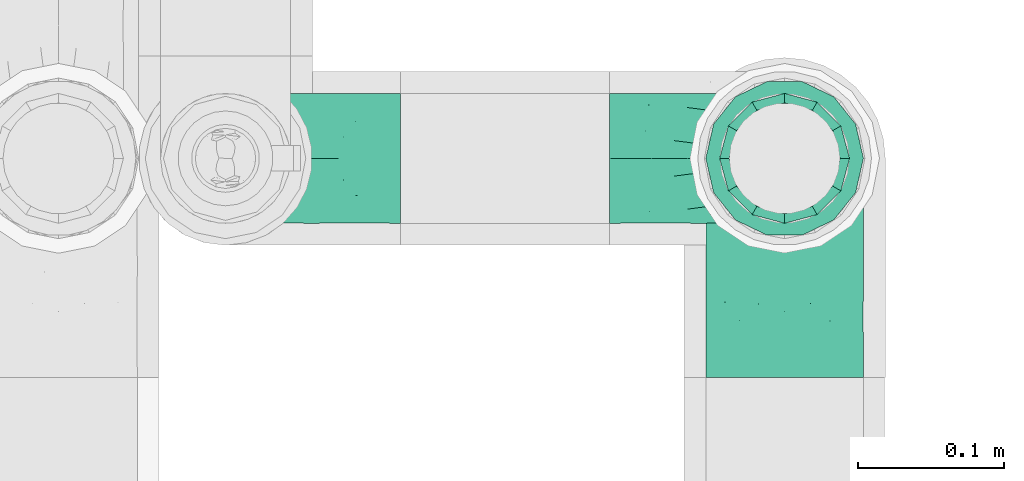
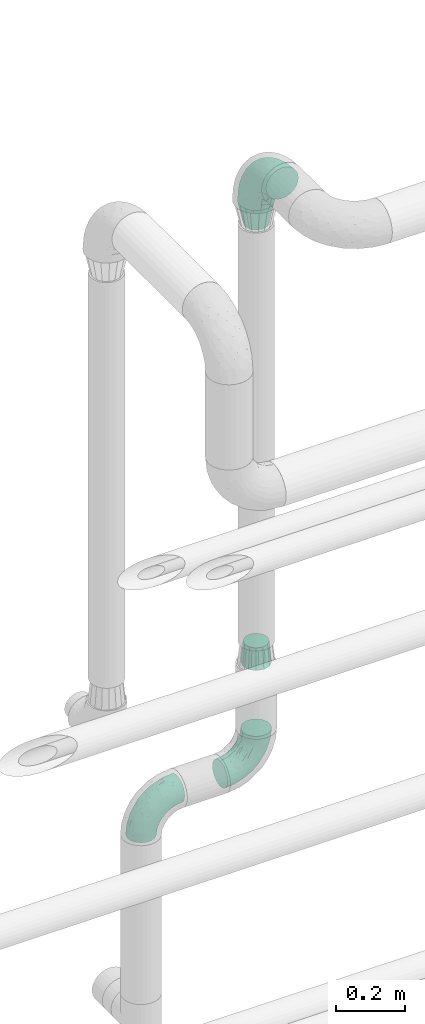
# One storey, part 721 of 827: 5 flow fittings.
"""IFC2X3 building model written with IfcOpenShell, lengths in millimetres."""

import ifcopenshell
import ifcopenshell.guid

model = None  # the IFC model being written
_history = None  # IfcOwnerHistory: only IFC2X3 demands one
_inside = {}  # id of a spatial element -> (the spatial element, [elements in it])
_under = {}  # id of a project, library or spatial element -> (it, [spatial elements below it])
_declared = {}  # id of a project -> (the project, [libraries it declares])
_typed = {}  # id of a type object -> (the type object, [elements of that type])
_made_of = {}  # id of a material, layer set ... -> (it, [elements and type objects made of it])


def new_model(schema):
    """Start an empty IFC model of exactly this schema.

    Asked for "IFC4X3", IfcOpenShell would pick the latest addendum, in which some entities
    have other attributes; the version numbers below select the first issue.
    IFC2X3 requires an IfcOwnerHistory on every rooted entity: one is made here for all.
    """
    global model, _history
    if schema == "IFC4X3":
        model = ifcopenshell.file(schema_version=(4, 3, 0, 0))
    else:
        model = ifcopenshell.file(schema=schema)
    _inside.clear()
    _under.clear()
    _declared.clear()
    _typed.clear()
    _made_of.clear()
    _history = None
    if model.schema == "IFC2X3":
        org = make("IfcOrganization", Name="unknown")
        user = make(
            "IfcPersonAndOrganization",
            ThePerson=make("IfcPerson", FamilyName="unknown"),
            TheOrganization=org,
        )
        app = make(
            "IfcApplication",
            ApplicationDeveloper=org,
            Version="unknown",
            ApplicationFullName="unknown",
            ApplicationIdentifier="unknown",
        )
        _history = make(
            "IfcOwnerHistory",
            OwningUser=user,
            OwningApplication=app,
            ChangeAction="ADDED",
            CreationDate=0,
        )
    return model


def make(cls, **values):
    """One entity of the class cls with the attributes given. An attribute that is None is left unset."""
    return model.create_entity(
        cls, **{name: value for name, value in values.items() if value is not None}
    )


def entity(cls, *values):
    """Any entity or typed value of the class cls, its attributes in the order of the schema. None: left unset."""
    e = model.create_entity(cls)
    for i, value in enumerate(values):
        if value is not None:
            e[i] = value
    return e


def rooted(cls, **values):
    """An entity with a GlobalId (a new one), such as an element, a storey or a relation."""
    return make(cls, GlobalId=ifcopenshell.guid.new(), OwnerHistory=_history, **values)


def si_unit(unit_type, name, prefix=None):
    """IfcSIUnit, for example si_unit("LENGTHUNIT", "METRE", prefix="MILLI")."""
    return make("IfcSIUnit", UnitType=unit_type, Prefix=prefix, Name=name)


def converted_unit(unit_type, name, factor, base, dimensions=None, offset=None):
    """IfcConversionBasedUnit, such as the inch: factor (a typed value) times the base unit."""
    return make(
        "IfcConversionBasedUnit"
        if offset is None
        else "IfcConversionBasedUnitWithOffset",
        ConversionOffset=offset,
        Dimensions=None
        if dimensions is None
        else entity("IfcDimensionalExponents", *dimensions),
        UnitType=unit_type,
        Name=name,
        ConversionFactor=make(
            "IfcMeasureWithUnit", ValueComponent=factor, UnitComponent=base
        ),
    )


def derived_unit(unit_type, elements):
    """IfcDerivedUnit: a product of units, each with its exponent."""
    return make(
        "IfcDerivedUnit",
        Elements=[
            make("IfcDerivedUnitElement", Unit=unit, Exponent=power)
            for unit, power in elements
        ],
        UnitType=unit_type,
    )


def assignment(units):
    """IfcUnitAssignment: the units of a project."""
    return None if units is None else make("IfcUnitAssignment", Units=units)


def point(xyz):
    """IfcCartesianPoint."""
    return None if xyz is None else make("IfcCartesianPoint", Coordinates=xyz)


def direction(xyz):
    """IfcDirection."""
    return None if xyz is None else make("IfcDirection", DirectionRatios=xyz)


def frame(location, z_axis=None, x_axis=None):
    """IfcAxis2Placement3D, a coordinate frame: its origin and axes. An axis left out is left unset."""
    return make(
        "IfcAxis2Placement3D",
        Location=point(location),
        Axis=direction(z_axis),
        RefDirection=direction(x_axis),
    )


def origin():
    """The frame at (0, 0, 0) with its axes left unset."""
    return frame((0.0, 0.0, 0.0))


def place(relative_to, where):
    """IfcLocalPlacement: puts the frame where relative to a parent placement (None: the world)."""
    return make(
        "IfcLocalPlacement", PlacementRelTo=relative_to, RelativePlacement=where
    )


def context(
    kind, dimensions, precision=None, world=None, true_north=None, identifier=None
):
    """IfcGeometricRepresentationContext, for example the 3D "Model" context."""
    return make(
        "IfcGeometricRepresentationContext",
        ContextIdentifier=identifier,
        ContextType=kind,
        CoordinateSpaceDimension=dimensions,
        Precision=precision,
        WorldCoordinateSystem=world,
        TrueNorth=true_north,
    )


def subcontext(parent, identifier, kind, view, scale=None):
    """IfcGeometricRepresentationSubContext, for example "Body" below "Model"."""
    return make(
        "IfcGeometricRepresentationSubContext",
        ContextIdentifier=identifier,
        ContextType=kind,
        ParentContext=parent,
        TargetScale=scale,
        TargetView=view,
    )


def project(units=None, contexts=None):
    """IfcProject with its units and contexts."""
    return rooted(
        "IfcProject",
        Name="project",
        RepresentationContexts=contexts,
        UnitsInContext=assignment(units),
    )


def spatial(cls, under=None, at=None, **own):
    """A site, building, storey or space (cls), placed at a placement, below another one or the project."""
    s = rooted(cls, ObjectPlacement=at, **own)
    if under is not None:
        _under.setdefault(under.id(), (under, []))[1].append(s)
    return s


def faces_of(points, faces, orient=None, outer=None):
    """IfcFace entities. A face is a list of loops; a loop is a list of indices into points, from 0.

    orient and outer hold one flag for each loop. By default every Orientation is true, the
    first loop of a face is its IfcFaceOuterBound and the others are IfcFaceBound.
    """
    made = []
    for i, loops in enumerate(faces):
        bounds = []
        for j, loop in enumerate(loops):
            is_outer = j == 0 if outer is None else outer[i][j]
            bounds.append(
                make(
                    "IfcFaceOuterBound" if is_outer else "IfcFaceBound",
                    Bound=make("IfcPolyLoop", Polygon=[points[k] for k in loop]),
                    Orientation=True if orient is None else orient[i][j],
                )
            )
        made.append(make("IfcFace", Bounds=bounds))
    return made


def faceted_brep(points, faces, orient=None, outer=None, voids=None):
    """IfcFacetedBrep: a solid bounded by flat faces; with voids (closed shells), ...WithVoids."""
    shared = [point(p) for p in points]
    hull = make("IfcClosedShell", CfsFaces=faces_of(shared, faces, orient, outer))
    if voids is None:
        return make("IfcFacetedBrep", Outer=hull)
    return make(
        "IfcFacetedBrepWithVoids",
        Outer=hull,
        Voids=[
            make(cls, CfsFaces=faces_of(shared, fs, o, b)) for cls, fs, o, b in voids
        ],
    )


def shape(context_of_items, identifier, shape_type, items):
    """IfcShapeRepresentation: the items that make up one representation, for example the "Body"."""
    return make(
        "IfcShapeRepresentation",
        ContextOfItems=context_of_items,
        RepresentationIdentifier=identifier,
        RepresentationType=shape_type,
        Items=items,
    )


def source(mapping_origin, context_of_items, identifier, shape_type, items):
    """IfcRepresentationMap: a shape defined once, which mapped items show again and again."""
    return make(
        "IfcRepresentationMap",
        MappingOrigin=mapping_origin,
        MappedRepresentation=shape(context_of_items, identifier, shape_type, items),
    )


def transform(
    local_origin,
    x_axis=None,
    y_axis=None,
    z_axis=None,
    scale=None,
    scale2=None,
    scale3=None,
    uniform=True,
):
    """IfcCartesianTransformationOperator3D, or its non-uniform kind. x_axis, y_axis, z_axis: its Axis1, 2, 3."""
    if uniform:
        return make(
            "IfcCartesianTransformationOperator3D",
            Axis1=direction(x_axis),
            Axis2=direction(y_axis),
            LocalOrigin=point(local_origin),
            Scale=scale,
            Axis3=direction(z_axis),
        )
    return make(
        "IfcCartesianTransformationOperator3DnonUniform",
        Axis1=direction(x_axis),
        Axis2=direction(y_axis),
        LocalOrigin=point(local_origin),
        Scale=scale,
        Axis3=direction(z_axis),
        Scale2=scale2,
        Scale3=scale3,
    )


def mapped(mapping_source, mapping_target):
    """IfcMappedItem: shows the shape of a source again, moved by a transform."""
    return make(
        "IfcMappedItem", MappingSource=mapping_source, MappingTarget=mapping_target
    )


def material(Name=None, Category=None):
    """IfcMaterial."""
    return make("IfcMaterial", Name=Name, Category=Category)


def made_of(thing, what):
    """Note that an element or type object is made of a material, layer set ...; save() writes the relation."""
    if what is not None:
        _made_of.setdefault(what.id(), (what, []))[1].append(thing)
    return thing


def type_object(cls, material=None, **own):
    """A type object (cls), such as IfcWallType, which elements share."""
    return made_of(rooted(cls, **own), material)


def type_shapes(of_type, sources):
    """Give a type object the sources (RepresentationMaps) that its elements show as mapped items."""
    of_type.RepresentationMaps = sources


def element(
    cls,
    number,
    at=None,
    inside=None,
    cuts=None,
    type_object=None,
    material=None,
    context=None,
    identifier="Body",
    shape_type=None,
    held_by="IfcProductDefinitionShape",
    body=None,
    shapes=None,
    **own,
):
    """One element of the class cls, such as IfcWall. Its Tag is "e" and its number.

    at: its placement. inside: the storey or other place that contains it. cuts: it is an
    opening in that element (IfcRelVoidsElement). A single representation is given by context,
    identifier, shape_type and body (its items); several are given by shapes. held_by: the class
    of the entity that holds the representations. save() writes the other relations.
    """
    e = rooted(cls, Tag="e%d" % number, ObjectPlacement=at, **own)
    if body is not None:
        shapes = [shape(context, identifier, shape_type, body)]
    if shapes is not None:
        e.Representation = make(held_by, Representations=shapes)
    if inside is not None:
        _inside.setdefault(inside.id(), (inside, []))[1].append(e)
    if cuts is not None:
        rooted(
            "IfcRelVoidsElement", RelatingBuildingElement=cuts, RelatedOpeningElement=e
        )
    if type_object is not None:
        _typed.setdefault(type_object.id(), (type_object, []))[1].append(e)
    return made_of(e, material)


def aggregate(whole, parts):
    """IfcRelAggregates: a whole, such as a stair, and the parts it consists of."""
    return rooted("IfcRelAggregates", RelatingObject=whole, RelatedObjects=parts)


def save(model, path):
    """Write the relations noted so far, then the file.

    IfcRelAggregates (storeys below a building ...), IfcRelContainedInSpatialStructure (elements
    in a storey), IfcRelDefinesByType, IfcRelAssociatesMaterial and IfcRelDeclares: one each for
    every whole, place, type object, material and project.
    """
    for whole, parts in _under.values():
        aggregate(whole, parts)
    for where, things in _inside.values():
        rooted(
            "IfcRelContainedInSpatialStructure",
            RelatedElements=things,
            RelatingStructure=where,
        )
    for kind, things in _typed.values():
        rooted("IfcRelDefinesByType", RelatedObjects=things, RelatingType=kind)
    for what, things in _made_of.values():
        rooted("IfcRelAssociatesMaterial", RelatedObjects=things, RelatingMaterial=what)
    for by, libraries in _declared.values():
        rooted("IfcRelDeclares", RelatingContext=by, RelatedDefinitions=libraries)
    model.write(path)


model = new_model("IFC2X3")

# Units and contexts
model_context = context("Model", 3, precision=0.01, world=origin(), true_north=direction((6.12303176911189e-17, 1.0)))
body_context = subcontext(model_context, "Body", "Model", "MODEL_VIEW")
ifc_project = project(units=[si_unit("LENGTHUNIT", "METRE", prefix="MILLI"), si_unit("AREAUNIT", "SQUARE_METRE"), si_unit("VOLUMEUNIT", "CUBIC_METRE"), converted_unit("PLANEANGLEUNIT", "DEGREE", entity("IfcRatioMeasure", 0.0174532925199433), si_unit("PLANEANGLEUNIT", "RADIAN"), dimensions=[0, 0, 0, 0, 0, 0, 0]), si_unit("MASSUNIT", "GRAM", prefix="KILO"), derived_unit("MASSDENSITYUNIT", [(si_unit("MASSUNIT", "GRAM", prefix="KILO"), 1), (si_unit("LENGTHUNIT", "METRE"), -3)]), derived_unit("MOMENTOFINERTIAUNIT", [(si_unit("LENGTHUNIT", "METRE"), 4)]), si_unit("TIMEUNIT", "SECOND"), si_unit("FREQUENCYUNIT", "HERTZ"), si_unit("THERMODYNAMICTEMPERATUREUNIT", "DEGREE_CELSIUS"), derived_unit("THERMALTRANSMITTANCEUNIT", [(si_unit("MASSUNIT", "GRAM", prefix="KILO"), 1), (si_unit("THERMODYNAMICTEMPERATUREUNIT", "KELVIN"), -1), (si_unit("TIMEUNIT", "SECOND"), -3)]), derived_unit("VOLUMETRICFLOWRATEUNIT", [(si_unit("LENGTHUNIT", "METRE"), 3), (si_unit("TIMEUNIT", "SECOND"), -1)]), derived_unit("MASSFLOWRATEUNIT", [(si_unit("MASSUNIT", "GRAM", prefix="KILO"), 1), (si_unit("TIMEUNIT", "SECOND"), -1)]), derived_unit("ROTATIONALFREQUENCYUNIT", [(si_unit("TIMEUNIT", "SECOND"), -1)]), si_unit("ELECTRICCURRENTUNIT", "AMPERE"), si_unit("ELECTRICVOLTAGEUNIT", "VOLT"), si_unit("POWERUNIT", "WATT"), si_unit("FORCEUNIT", "NEWTON", prefix="KILO"), si_unit("ILLUMINANCEUNIT", "LUX"), si_unit("LUMINOUSFLUXUNIT", "LUMEN"), si_unit("LUMINOUSINTENSITYUNIT", "CANDELA"), derived_unit("USERDEFINED", [(si_unit("MASSUNIT", "GRAM", prefix="KILO"), -1), (si_unit("LENGTHUNIT", "METRE"), -2), (si_unit("TIMEUNIT", "SECOND"), 3), (si_unit("LUMINOUSFLUXUNIT", "LUMEN"), 1)]), derived_unit("LINEARVELOCITYUNIT", [(si_unit("LENGTHUNIT", "METRE"), 1), (si_unit("TIMEUNIT", "SECOND"), -1)]), si_unit("PRESSUREUNIT", "PASCAL"), derived_unit("USERDEFINED", [(si_unit("LENGTHUNIT", "METRE"), -2), (si_unit("MASSUNIT", "GRAM", prefix="KILO"), 1), (si_unit("TIMEUNIT", "SECOND"), -2)]), derived_unit("LINEARFORCEUNIT", [(si_unit("MASSUNIT", "GRAM", prefix="KILO"), 1), (si_unit("LENGTHUNIT", "METRE"), 1), (si_unit("TIMEUNIT", "SECOND"), -2), (si_unit("LENGTHUNIT", "METRE"), -1)]), derived_unit("PLANARFORCEUNIT", [(si_unit("MASSUNIT", "GRAM", prefix="KILO"), 1), (si_unit("LENGTHUNIT", "METRE"), 1), (si_unit("TIMEUNIT", "SECOND"), -2), (si_unit("LENGTHUNIT", "METRE"), -2)])], contexts=[model_context])

# Site, building, storey
site_placement = place(None, origin())
site = spatial("IfcSite", under=ifc_project, at=site_placement, CompositionType="ELEMENT")
building_placement = place(site_placement, origin())
building = spatial("IfcBuilding", under=site, at=building_placement, CompositionType="ELEMENT")
storey_placement = place(building_placement, frame((0.0, 0.0, 28200.0)))
storey = spatial("IfcBuildingStorey", under=building, at=storey_placement, Name="08", CompositionType="ELEMENT", Elevation=28200.0)

# Flow fittings
ifc_material = material()
pipe_fitting_type_1 = type_object("IfcPipeFittingType", Name="ADSK_2", PredefinedType="NOTDEFINED", material=ifc_material)
shared_shape_1 = source(origin(), body_context, "Body", "Brep", [
    faceted_brep([(-150.0, 13.98, -52.16), (-150.0, 0.0, -54.0), (-150.0, -13.98, -52.16), (-150.0, -27.0, -46.77), (-150.0, -38.18, -38.18), (-150.0, -46.77, -27.0), (-150.0, -52.16, -13.98), (-150.0, -54.0, 0.0), (-150.0, -52.16, 13.98), (-150.0, -46.77, 27.0), (-150.0, -38.18, 38.18), (-150.0, -27.0, 46.77), (-150.0, -13.98, 52.16), (-150.0, 0.0, 54.0), (-150.0, 13.98, 52.16), (-150.0, 27.0, 46.77), (-150.0, 38.18, 38.18), (-150.0, 46.77, 27.0), (-150.0, 52.16, 13.98), (-150.0, 54.0, 0.0), (-150.0, 52.16, -13.98), (-150.0, 46.77, -27.0), (-150.0, 38.18, -38.18), (-150.0, 27.0, -46.77), (-46.77, 150.0, -27.0), (-52.16, 150.0, -13.98), (-54.0, 150.0, 0.0), (-52.16, 150.0, 13.98), (-46.77, 150.0, 27.0), (-38.18, 150.0, 38.18), (-27.0, 150.0, 46.77), (-13.98, 150.0, 52.16), (0.0, 150.0, 54.0), (13.98, 150.0, 52.16), (27.0, 150.0, 46.77), (38.18, 150.0, 38.18), (46.77, 150.0, 27.0), (52.16, 150.0, 13.98), (54.0, 150.0, 0.0), (52.16, 150.0, -13.98), (46.77, 150.0, -27.0), (38.18, 150.0, -38.18), (27.0, 150.0, -46.77), (13.98, 150.0, -52.16), (0.0, 150.0, -54.0), (-13.98, 150.0, -52.16), (-27.0, 150.0, -46.77), (-38.18, 150.0, -38.18), (-23.02, 116.05, 50.71), (-10.79, 106.96, 53.83), (-99.79, -44.6, 17.82), (-104.61, -48.89, 0.0), (-111.52, -18.45, 48.95), (-64.27, -5.9, 46.22), (-79.66, 4.7, 52.78), (-22.81, -9.49, 0.0), (-44.33, -22.22, 14.35), (-61.49, -33.8, 0.0), (-111.02, -40.26, 31.0), (-106.96, 10.79, 53.83), (-75.79, 19.35, 54.0), (-83.79, 28.63, 52.71), (-6.35, 6.35, 9.57), (22.22, 44.33, 14.35), (-8.95, 8.95, 21.66), (-70.7, -34.05, 19.37), (-77.79, -39.89, 9.53), (-98.78, -28.03, 40.91), (-35.45, -0.96, 36.82), (-24.08, 24.08, 46.13), (-116.99, -5.61, 53.23), (-84.48, 39.18, 49.64), (-116.05, 23.02, 50.71), (28.03, 98.78, 40.91), (-30.84, 79.95, 52.7), (-19.51, 75.72, 54.0), (-52.23, 125.53, 22.23), (-63.5, 102.33, 17.08), (-52.58, 23.63, 53.15), (-23.76, 41.59, 51.45), (-36.39, 47.25, 53.91), (-58.7, 120.33, 0.0), (-125.53, 52.23, 22.23), (-102.33, 63.5, 17.08), (-120.33, 58.7, 0.0), (-59.32, 99.83, 27.68), (-79.36, 79.36, 20.15), (-75.61, 75.61, 30.15), (-114.52, 47.22, 34.83), (-126.22, 33.98, 43.81), (-93.57, 72.33, 0.0), (-47.51, 113.57, 34.88), (18.45, 111.52, 48.95), (5.61, 116.99, 53.23), (48.89, 104.61, 0.0), (44.6, 99.79, 17.82), (37.15, 71.79, 11.16), (5.9, 64.27, 46.22), (-4.7, 79.66, 52.78), (35.09, 74.65, 20.78), (40.26, 111.02, 31.0), (26.44, 65.11, 28.6), (-65.6, -16.94, 39.27), (-65.11, -26.44, 28.6), (-81.51, 81.51, 9.56), (-72.33, 93.57, 0.0), (9.49, 22.81, 0.0), (-35.64, -11.82, 24.43), (-34.23, 124.56, 43.88), (-43.22, 94.57, 45.11), (-69.02, 56.15, 47.3), (-59.26, 74.56, 43.5), (-78.28, 61.88, 39.9), (18.71, 65.93, 37.87), (0.96, 35.45, 36.82), (-59.2, 87.93, 36.27), (33.8, 61.49, 0.0), (-97.33, 42.02, 44.99), (-99.65, 59.35, 27.78), (-56.16, 9.04, 50.42), (11.82, 35.64, 24.43), (-49.6, 72.87, 48.67), (-34.04, 93.29, 49.78), (-57.05, 51.22, 52.06), (-124.56, 34.23, -43.88), (-98.78, -28.03, -40.91), (-79.66, 4.7, -52.78), (-116.99, -5.61, -53.23), (-106.96, 10.79, -53.83), (-99.83, 59.32, -27.68), (-113.57, 47.51, -34.88), (-125.53, 52.23, -22.23), (-116.05, 23.02, -50.71), (-79.95, 30.84, -52.7), (-47.22, 114.52, -34.83), (-102.33, 63.5, -17.08), (40.26, 111.02, -31.0), (-81.51, 81.51, -9.56), (-52.23, 125.53, -22.23), (-94.57, 43.22, -45.11), (-64.27, -5.9, -46.22), (-35.45, -0.96, -36.82), (-65.93, -18.71, -37.87), (-99.79, -44.6, -17.82), (-47.25, 36.39, -53.91), (-75.72, 19.51, -54.0), (-39.18, 84.48, -49.64), (-23.02, 116.05, -50.71), (-28.63, 83.79, -52.71), (-111.02, -40.26, -31.0), (-10.79, 106.96, -53.83), (-19.35, 75.79, -54.0), (-44.33, -22.22, -14.35), (-8.95, 8.95, -21.66), (-6.35, 6.35, -9.57), (-71.79, -37.15, -11.16), (-61.88, 78.28, -39.9), (-74.56, 59.26, -43.5), (-87.93, 59.2, -36.27), (-74.65, -35.09, -20.78), (-65.11, -26.44, -28.6), (0.96, 35.45, -36.82), (-63.5, 102.33, -17.08), (-79.36, 79.36, -20.15), (18.45, 111.52, -48.95), (5.9, 64.27, -46.22), (-4.7, 79.66, -52.78), (-75.61, 75.61, -30.15), (-33.98, 126.22, -43.81), (5.61, 116.99, -53.23), (-23.63, 52.58, -53.15), (-41.59, 23.76, -51.45), (22.22, 44.33, -14.35), (-56.15, 69.02, -47.3), (28.03, 98.78, -40.91), (39.89, 77.79, -9.53), (34.05, 70.7, -19.37), (-111.52, -18.45, -48.95), (44.6, 99.79, -17.82), (26.44, 65.11, -28.6), (11.82, 35.64, -24.43), (16.94, 65.6, -39.27), (-42.02, 97.33, -44.99), (-59.35, 99.65, -27.78), (-24.08, 24.08, -46.13), (-9.04, 56.16, -50.42), (-35.64, -11.82, -24.43), (-72.87, 49.6, -48.67), (-93.29, 34.04, -49.78), (-51.22, 57.05, -52.06)], [[[0, 1, 2, 3, 4, 5, 6, 7, 8, 9, 10, 11, 12, 13, 14, 15, 16, 17, 18, 19, 20, 21, 22, 23]], [[24, 25, 26, 27, 28, 29, 30, 31, 32, 33, 34, 35, 36, 37, 38, 39, 40, 41, 42, 43, 44, 45, 46, 47]], [[31, 48, 49]], [[50, 8, 51]], [[52, 53, 54]], [[8, 50, 9]], [[8, 7, 51]], [[55, 56, 57]], [[58, 9, 50]], [[59, 60, 61]], [[62, 63, 64]], [[65, 66, 56]], [[11, 10, 67]], [[53, 68, 69]], [[67, 52, 11]], [[70, 59, 13]], [[71, 72, 61]], [[73, 35, 34]], [[74, 75, 49]], [[72, 15, 14]], [[13, 59, 14]], [[76, 27, 77]], [[12, 70, 13]], [[78, 79, 80]], [[27, 81, 77]], [[18, 82, 83]], [[72, 14, 59]], [[84, 19, 18]], [[85, 86, 87]], [[88, 16, 89]], [[84, 83, 90]], [[84, 18, 83]], [[15, 89, 16]], [[85, 91, 76]], [[92, 73, 34]], [[49, 32, 31]], [[93, 33, 32]], [[31, 30, 48]], [[94, 95, 96]], [[94, 37, 95]], [[73, 92, 97]], [[98, 93, 49]], [[11, 52, 12]], [[36, 95, 37]], [[99, 100, 101]], [[95, 36, 100]], [[63, 96, 99]], [[100, 36, 35]], [[102, 53, 67]], [[38, 37, 94]], [[92, 34, 33]], [[103, 67, 58]], [[81, 27, 26]], [[104, 105, 90]], [[106, 62, 55]], [[9, 58, 10]], [[91, 29, 28]], [[77, 81, 105]], [[107, 103, 65]], [[49, 48, 74]], [[83, 86, 104]], [[108, 91, 109]], [[16, 88, 17]], [[110, 111, 112]], [[113, 114, 101]], [[108, 30, 29]], [[113, 97, 114]], [[112, 111, 115]], [[66, 51, 57]], [[63, 106, 116]], [[74, 80, 75]], [[82, 18, 17]], [[76, 28, 27]], [[115, 91, 85]], [[112, 88, 117]], [[118, 83, 82]], [[58, 50, 65]], [[67, 10, 58]], [[35, 73, 100]], [[101, 100, 73]], [[53, 52, 67]], [[70, 52, 54]], [[102, 103, 68]], [[119, 78, 54]], [[93, 92, 33]], [[98, 79, 97]], [[98, 97, 92]], [[97, 69, 114]], [[56, 55, 62]], [[56, 107, 65]], [[96, 63, 116]], [[63, 99, 120]], [[108, 48, 30]], [[121, 74, 122]], [[61, 72, 59]], [[89, 72, 117]], [[107, 68, 103]], [[64, 120, 114]], [[69, 68, 114]], [[64, 114, 68]], [[122, 74, 48]], [[74, 123, 80]], [[123, 61, 60]], [[80, 60, 78]], [[49, 93, 32]], [[92, 93, 98]], [[52, 70, 12]], [[59, 70, 54]], [[59, 54, 60]], [[123, 110, 71]], [[78, 60, 54]], [[123, 60, 80]], [[119, 54, 53]], [[78, 119, 79]], [[97, 79, 69]], [[98, 80, 79]], [[53, 69, 119]], [[79, 119, 69]], [[91, 108, 29]], [[108, 109, 122]], [[85, 76, 77]], [[91, 28, 76]], [[86, 85, 77]], [[115, 85, 87]], [[112, 115, 87]], [[109, 91, 115]], [[112, 87, 118]], [[112, 117, 110]], [[71, 110, 117]], [[122, 109, 121]], [[17, 88, 82]], [[118, 87, 86]], [[82, 88, 118]], [[112, 118, 88]], [[80, 98, 75]], [[98, 49, 75]], [[111, 110, 121]], [[115, 111, 109]], [[72, 89, 15]], [[88, 89, 117]], [[72, 71, 117]], [[123, 71, 61]], [[77, 105, 104]], [[118, 86, 83]], [[83, 104, 90]], [[77, 104, 86]], [[63, 62, 106]], [[56, 62, 64]], [[56, 64, 107]], [[68, 107, 64]], [[58, 65, 103]], [[66, 65, 50]], [[51, 66, 50]], [[56, 66, 57]], [[94, 96, 116]], [[99, 96, 95]], [[100, 99, 95]], [[99, 101, 120]], [[114, 120, 101]], [[64, 63, 120]], [[103, 102, 67]], [[68, 53, 102]], [[101, 73, 113]], [[97, 113, 73]], [[108, 122, 48]], [[111, 121, 109]], [[110, 123, 121]], [[74, 121, 123]], [[22, 124, 23]], [[125, 4, 3]], [[126, 127, 128]], [[129, 130, 131]], [[132, 133, 128]], [[128, 1, 0]], [[19, 84, 20]], [[47, 134, 24]], [[90, 135, 84]], [[40, 136, 41]], [[105, 137, 90]], [[131, 20, 135]], [[138, 25, 24]], [[139, 124, 130]], [[130, 22, 21]], [[140, 141, 142]], [[5, 143, 6]], [[133, 144, 145]], [[51, 7, 6]], [[146, 147, 148]], [[143, 5, 149]], [[150, 151, 148]], [[57, 152, 55]], [[153, 154, 152]], [[20, 84, 135]], [[143, 51, 6]], [[143, 155, 51]], [[156, 157, 158]], [[127, 2, 1]], [[159, 149, 160]], [[0, 23, 132]], [[141, 161, 153]], [[162, 163, 137]], [[42, 164, 43]], [[164, 165, 166]], [[44, 150, 45]], [[163, 167, 129]], [[25, 81, 26]], [[0, 132, 128]], [[162, 25, 138]], [[147, 46, 45]], [[47, 168, 134]], [[43, 169, 44]], [[170, 171, 144]], [[81, 25, 162]], [[46, 168, 47]], [[106, 172, 116]], [[150, 147, 45]], [[173, 157, 156]], [[42, 174, 164]], [[55, 154, 106]], [[174, 42, 41]], [[169, 150, 44]], [[175, 172, 176]], [[125, 3, 177]], [[133, 145, 128]], [[178, 40, 39]], [[179, 174, 136]], [[38, 94, 39]], [[152, 155, 159]], [[149, 5, 4]], [[178, 39, 94]], [[175, 94, 116]], [[40, 178, 136]], [[177, 3, 2]], [[179, 176, 180]], [[125, 177, 140]], [[162, 105, 81]], [[181, 165, 174]], [[160, 142, 141]], [[131, 21, 20]], [[158, 130, 129]], [[156, 134, 182]], [[183, 162, 138]], [[4, 125, 149]], [[160, 149, 125]], [[136, 178, 176]], [[174, 41, 136]], [[127, 177, 2]], [[126, 171, 140]], [[126, 140, 177]], [[140, 184, 141]], [[165, 164, 174]], [[169, 164, 166]], [[181, 179, 161]], [[185, 170, 166]], [[155, 152, 57]], [[152, 159, 186]], [[172, 106, 154]], [[172, 180, 176]], [[124, 132, 23]], [[187, 133, 188]], [[148, 147, 150]], [[168, 147, 182]], [[161, 184, 165]], [[186, 141, 153]], [[161, 179, 180]], [[141, 184, 161]], [[188, 133, 132]], [[133, 189, 144]], [[189, 148, 151]], [[144, 151, 170]], [[128, 127, 1]], [[177, 127, 126]], [[164, 169, 43]], [[150, 169, 166]], [[150, 166, 151]], [[189, 173, 146]], [[170, 151, 166]], [[189, 151, 144]], [[185, 166, 165]], [[170, 185, 171]], [[140, 171, 184]], [[126, 144, 171]], [[165, 184, 185]], [[171, 185, 184]], [[130, 124, 22]], [[124, 139, 188]], [[129, 131, 135]], [[130, 21, 131]], [[163, 129, 135]], [[158, 129, 167]], [[156, 158, 167]], [[139, 130, 158]], [[156, 167, 183]], [[156, 182, 173]], [[146, 173, 182]], [[188, 139, 187]], [[24, 134, 138]], [[183, 167, 163]], [[138, 134, 183]], [[156, 183, 134]], [[144, 126, 145]], [[126, 128, 145]], [[157, 173, 187]], [[158, 157, 139]], [[147, 168, 46]], [[134, 168, 182]], [[147, 146, 182]], [[189, 146, 148]], [[135, 90, 137]], [[183, 163, 162]], [[162, 137, 105]], [[135, 137, 163]], [[152, 154, 55]], [[172, 154, 153]], [[51, 155, 57]], [[159, 155, 143]], [[149, 159, 143]], [[159, 160, 186]], [[141, 186, 160]], [[153, 152, 186]], [[172, 153, 180]], [[161, 180, 153]], [[136, 176, 179]], [[175, 176, 178]], [[94, 175, 178]], [[172, 175, 116]], [[160, 125, 142]], [[140, 142, 125]], [[179, 181, 174]], [[161, 165, 181]], [[124, 188, 132]], [[157, 187, 139]], [[173, 189, 187]], [[133, 187, 189]]]),
])
type_shapes(pipe_fitting_type_1, [shared_shape_1])
flow_fitting_1_placement = place(storey_placement, frame((56108.55, 18635.99, 3499.74), z_axis=(-1.0, 0.0, 0.0), x_axis=(0.0, 1.0, 0.0)))
element("IfcFlowFitting", 1, at=flow_fitting_1_placement, inside=storey, type_object=pipe_fitting_type_1, material=ifc_material, Name="ADSK_2", ObjectType="ADSK_2", context=body_context, shape_type="MappedRepresentation", body=[
    mapped(shared_shape_1, transform((0.0, 0.0, 0.0), scale=1.0)),
])
pipe_fitting_type_2 = type_object("IfcPipeFittingType", Name="ADSK_2", PredefinedType="NOTDEFINED", material=ifc_material)
shared_shape_2 = source(origin(), body_context, "Body", "Brep", [
    faceted_brep([(-120.0, 22.25, -38.54), (-120.0, 11.52, -42.98), (-120.0, 0.0, -44.5), (-120.0, -11.52, -42.98), (-120.0, -22.25, -38.54), (-120.0, -31.47, -31.47), (-120.0, -38.54, -22.25), (-120.0, -42.98, -11.52), (-120.0, -44.5, 0.0), (-120.0, -42.98, 11.52), (-120.0, -38.54, 22.25), (-120.0, -31.47, 31.47), (-120.0, -22.25, 38.54), (-120.0, -11.52, 42.98), (-120.0, 0.0, 44.5), (-120.0, 11.52, 42.98), (-120.0, 22.25, 38.54), (-120.0, 31.47, 31.47), (-120.0, 38.54, 22.25), (-120.0, 42.98, 11.52), (-120.0, 44.5, 0.0), (-120.0, 42.98, -11.52), (-120.0, 38.54, -22.25), (-120.0, 31.47, -31.47), (0.0, 120.0, -44.5), (-11.52, 120.0, -42.98), (-22.25, 120.0, -38.54), (-31.47, 120.0, -31.47), (-38.54, 120.0, -22.25), (-42.98, 120.0, -11.52), (-44.5, 120.0, 0.0), (-42.98, 120.0, 11.52), (-38.54, 120.0, 22.25), (-31.47, 120.0, 31.47), (-22.25, 120.0, 38.54), (-11.52, 120.0, 42.98), (0.0, 120.0, 44.5), (11.52, 120.0, 42.98), (22.25, 120.0, 38.54), (31.47, 120.0, 31.47), (38.54, 120.0, 22.25), (42.98, 120.0, 11.52), (44.5, 120.0, 0.0), (42.98, 120.0, -11.52), (38.54, 120.0, -22.25), (31.47, 120.0, -31.47), (22.25, 120.0, -38.54), (11.52, 120.0, -42.98), (-20.51, 85.66, 41.98), (-29.31, 93.55, 36.45), (-98.0, -41.6, 0.0), (-80.92, -37.22, 14.68), (-66.68, -9.63, 39.67), (-84.59, -24.55, 33.9), (-50.35, -12.87, 32.85), (-77.42, -38.89, 0.0), (-22.01, -9.62, 13.21), (-37.75, -22.46, 0.0), (-20.72, -9.39, 0.0), (-89.18, -33.47, 25.4), (12.87, 50.35, 32.85), (24.55, 84.59, 33.9), (9.63, 66.68, 39.67), (-49.55, -27.06, 11.21), (-28.67, -9.99, 21.67), (-52.01, -22.41, 23.47), (-95.53, -16.28, 40.49), (-86.01, -3.42, 43.77), (22.41, 52.01, 23.47), (9.05, 21.37, 13.44), (26.5, 49.37, 12.73), (33.47, 89.18, 25.4), (37.22, 80.92, 14.68), (16.28, 95.53, 40.49), (3.42, 86.01, 43.77), (-7.84, 52.6, 43.16), (-84.39, 31.88, 36.84), (-30.52, 34.28, 44.33), (-21.99, 28.55, 42.22), (-93.56, 38.23, 28.63), (-65.04, 31.74, 41.51), (-91.98, 19.0, 41.83), (-34.03, 70.24, 39.41), (-96.36, 44.0, 18.64), (-98.49, 46.74, 8.65), (-76.5, 56.97, 9.76), (-4.96, 4.47, 11.32), (-7.16, 6.18, 18.93), (-56.62, 75.93, 12.18), (-66.61, 66.61, 0.0), (-92.12, 7.25, 44.33), (-7.23, 92.66, 44.32), (30.68, 57.59, 0.0), (-44.45, 94.8, 18.75), (-36.39, 101.98, 28.14), (-46.83, 97.45, 9.69), (-38.03, 47.61, 43.21), (-24.7, 65.7, 43.29), (41.6, 98.0, 0.0), (-54.11, 72.8, 21.53), (-47.95, 9.75, 42.93), (-18.65, 18.65, 37.89), (-91.11, 50.25, 0.0), (-50.25, 91.11, 0.0), (-57.59, -30.68, 0.0), (-44.16, 67.2, 34.92), (-55.15, 62.16, 29.74), (-68.1, 47.21, 32.31), (-51.09, 51.09, 38.36), (-16.69, 62.62, 44.46), (-58.26, 18.84, 44.48), (-71.55, 55.71, 20.49), (-43.13, 80.04, 29.45), (-37.23, 0.88, 36.78), (-18.15, 10.22, 33.09), (5.51, 28.08, 26.74), (-3.68, 3.68, 0.0), (9.39, 20.72, 0.0), (-2.58, 27.98, 33.59), (-2.38, 41.22, 38.93), (-16.09, 4.55, 27.06), (38.89, 77.42, 0.0), (22.46, 37.75, 0.0), (-92.66, 7.23, -44.32), (-22.01, -9.62, -13.21), (-49.81, -26.66, -12.91), (-28.67, -9.99, -21.67), (-62.62, 16.69, -44.46), (-65.04, 31.74, -41.51), (-38.89, 47.26, -43.11), (-56.62, 75.93, -12.18), (-93.56, 38.23, -28.63), (-84.39, 31.88, -36.84), (16.28, 95.53, -40.49), (3.42, 86.01, -43.77), (-98.49, 46.74, -8.65), (-44.45, 94.8, -18.75), (-54.11, 72.8, -21.53), (-76.5, 56.97, -9.76), (24.55, 84.59, -33.9), (9.63, 66.68, -39.67), (-96.36, 44.0, -18.64), (-29.4, 93.16, -36.47), (-91.98, 19.0, -41.83), (-80.92, -37.22, -14.68), (-52.6, 7.84, -43.16), (-86.01, -3.42, -43.77), (-89.18, -33.47, -25.4), (-52.01, -22.41, -23.47), (-50.35, -12.87, -32.85), (-84.59, -24.55, -33.9), (-66.68, -9.63, -39.67), (-95.53, -16.28, -40.49), (-68.1, 47.21, -32.31), (-35.81, 11.1, -40.85), (-19.61, 28.53, -41.59), (-18.65, 18.65, -37.89), (-4.97, 4.47, -11.34), (9.05, 21.37, -13.44), (-34.28, 30.52, -44.33), (-9.75, 47.95, -42.93), (-2.58, 27.98, -33.59), (-18.15, 10.22, -33.09), (-46.83, 97.45, -9.69), (12.87, 50.35, -32.85), (26.8, 49.13, -11.4), (-7.34, 92.03, -44.33), (-21.02, 83.86, -42.03), (-44.6, 66.82, -34.8), (-55.46, 62.18, -29.47), (37.22, 80.92, -14.68), (33.47, 89.18, -25.4), (-34.39, 70.11, -39.28), (-25.04, 64.41, -43.37), (-18.84, 58.26, -44.48), (22.41, 52.01, -23.47), (-36.39, 101.98, -28.14), (-51.09, 51.09, -38.36), (-43.13, 80.04, -29.45), (-71.55, 55.71, -20.49), (-7.15, 6.2, -18.94), (5.51, 28.08, -26.74), (-37.23, 0.88, -36.78), (-2.38, 41.22, -38.93), (-16.09, 4.55, -27.06)], [[[0, 1, 2, 3, 4, 5, 6, 7, 8, 9, 10, 11, 12, 13, 14, 15, 16, 17, 18, 19, 20, 21, 22, 23]], [[24, 25, 26, 27, 28, 29, 30, 31, 32, 33, 34, 35, 36, 37, 38, 39, 40, 41, 42, 43, 44, 45, 46, 47]], [[48, 34, 49]], [[50, 51, 9]], [[52, 53, 54]], [[9, 51, 10]], [[55, 51, 50]], [[56, 57, 58]], [[51, 59, 10]], [[60, 61, 62]], [[63, 64, 65]], [[13, 12, 66]], [[67, 14, 13]], [[68, 69, 70]], [[71, 68, 72]], [[38, 73, 61]], [[74, 75, 62]], [[17, 16, 76]], [[77, 78, 75]], [[79, 18, 17]], [[80, 76, 81]], [[35, 34, 48]], [[49, 82, 48]], [[18, 83, 19]], [[16, 81, 76]], [[20, 19, 84]], [[85, 84, 83]], [[56, 86, 87]], [[85, 88, 89]], [[37, 36, 74]], [[90, 14, 67]], [[79, 17, 76]], [[63, 65, 51]], [[13, 66, 67]], [[61, 39, 38]], [[91, 74, 36]], [[70, 92, 72]], [[93, 94, 32]], [[95, 88, 93]], [[62, 73, 74]], [[82, 96, 97]], [[40, 72, 41]], [[72, 68, 70]], [[71, 72, 40]], [[34, 33, 49]], [[72, 98, 41]], [[99, 93, 88]], [[71, 39, 61]], [[78, 100, 101]], [[85, 89, 102]], [[53, 52, 66]], [[103, 95, 30]], [[12, 11, 53]], [[103, 89, 88]], [[104, 57, 63]], [[91, 48, 97]], [[93, 32, 31]], [[33, 32, 94]], [[16, 15, 81]], [[105, 106, 107]], [[76, 107, 79]], [[35, 91, 36]], [[80, 96, 108]], [[31, 95, 93]], [[65, 53, 59]], [[73, 38, 37]], [[75, 74, 109]], [[61, 60, 68]], [[11, 10, 59]], [[54, 53, 65]], [[100, 67, 52]], [[110, 81, 90]], [[15, 14, 90]], [[76, 80, 108]], [[107, 76, 108]], [[83, 79, 111]], [[94, 49, 33]], [[82, 105, 108]], [[84, 85, 102]], [[111, 88, 85]], [[99, 88, 111]], [[94, 93, 112]], [[48, 91, 35]], [[74, 91, 109]], [[69, 87, 86]], [[113, 54, 114]], [[64, 56, 87]], [[60, 115, 68]], [[116, 117, 86]], [[69, 68, 115]], [[79, 83, 18]], [[85, 83, 111]], [[81, 110, 80]], [[110, 77, 96]], [[110, 96, 80]], [[97, 96, 109]], [[107, 108, 105]], [[111, 79, 107]], [[77, 75, 109]], [[118, 119, 101]], [[96, 77, 109]], [[77, 110, 100]], [[67, 100, 110]], [[100, 52, 113]], [[60, 119, 118]], [[118, 120, 115]], [[64, 54, 65]], [[114, 120, 118]], [[118, 115, 60]], [[115, 120, 87]], [[74, 73, 37]], [[61, 73, 62]], [[53, 66, 12]], [[67, 66, 52]], [[110, 90, 67]], [[15, 90, 81]], [[105, 49, 112]], [[96, 82, 108]], [[119, 60, 62]], [[118, 101, 114]], [[62, 75, 119]], [[78, 119, 75]], [[49, 105, 82]], [[105, 112, 106]], [[99, 112, 93]], [[111, 107, 106]], [[113, 114, 101]], [[54, 120, 114]], [[100, 113, 101]], [[52, 54, 113]], [[20, 84, 102]], [[83, 84, 19]], [[111, 106, 99]], [[112, 99, 106]], [[100, 78, 77]], [[119, 78, 101]], [[39, 71, 40]], [[68, 71, 61]], [[65, 59, 51]], [[11, 59, 53]], [[30, 95, 31]], [[103, 88, 95]], [[9, 8, 50]], [[98, 72, 121]], [[98, 42, 41]], [[49, 94, 112]], [[56, 63, 57]], [[51, 55, 104]], [[92, 121, 72]], [[86, 58, 116]], [[54, 64, 120]], [[115, 87, 69]], [[120, 64, 87]], [[58, 86, 56]], [[86, 117, 69]], [[91, 97, 109]], [[122, 69, 117]], [[82, 97, 48]], [[63, 56, 64]], [[104, 63, 51]], [[69, 122, 70]], [[92, 70, 122]], [[123, 2, 1]], [[124, 125, 126]], [[127, 128, 129]], [[103, 130, 89]], [[23, 131, 132]], [[47, 133, 134]], [[102, 135, 20]], [[130, 136, 137]], [[102, 138, 135]], [[139, 140, 133]], [[22, 21, 141]], [[27, 26, 142]], [[46, 45, 139]], [[0, 143, 1]], [[6, 144, 7]], [[145, 146, 127]], [[144, 50, 7]], [[147, 148, 144]], [[144, 6, 147]], [[149, 150, 151]], [[4, 3, 152]], [[23, 22, 131]], [[132, 131, 153]], [[43, 42, 98]], [[125, 104, 144]], [[154, 155, 156]], [[146, 151, 152]], [[4, 150, 5]], [[123, 146, 2]], [[157, 158, 117]], [[130, 138, 89]], [[29, 28, 136]], [[159, 160, 155]], [[161, 162, 156]], [[89, 138, 102]], [[163, 30, 29]], [[164, 140, 139]], [[163, 136, 130]], [[23, 132, 0]], [[158, 165, 122]], [[25, 24, 166]], [[0, 132, 143]], [[4, 152, 150]], [[142, 26, 167]], [[3, 2, 146]], [[167, 26, 25]], [[133, 47, 46]], [[168, 153, 169]], [[146, 145, 151]], [[149, 126, 148]], [[44, 170, 171]], [[24, 47, 134]], [[170, 44, 43]], [[144, 148, 125]], [[170, 98, 121]], [[168, 142, 172]], [[129, 173, 174]], [[98, 170, 43]], [[147, 5, 150]], [[157, 58, 124]], [[92, 122, 165]], [[134, 166, 24]], [[175, 139, 171]], [[28, 27, 176]], [[29, 136, 163]], [[132, 128, 143]], [[45, 44, 171]], [[164, 139, 175]], [[160, 134, 140]], [[174, 173, 166]], [[141, 131, 22]], [[132, 153, 177]], [[128, 132, 177]], [[123, 143, 127]], [[172, 142, 167]], [[176, 142, 178]], [[130, 179, 138]], [[138, 179, 141]], [[176, 136, 28]], [[130, 137, 179]], [[174, 166, 134]], [[167, 25, 166]], [[143, 123, 1]], [[146, 123, 127]], [[150, 149, 148]], [[157, 124, 180]], [[181, 161, 164]], [[181, 158, 180]], [[124, 126, 180]], [[170, 165, 175]], [[141, 21, 135]], [[131, 141, 179]], [[131, 179, 153]], [[179, 137, 169]], [[129, 128, 177]], [[127, 143, 128]], [[129, 177, 172]], [[129, 174, 159]], [[159, 145, 127]], [[182, 154, 156]], [[129, 159, 127]], [[159, 174, 160]], [[134, 160, 174]], [[140, 164, 183]], [[162, 182, 156]], [[126, 149, 184]], [[181, 164, 175]], [[164, 161, 183]], [[158, 181, 175]], [[184, 162, 161]], [[146, 152, 3]], [[150, 152, 151]], [[139, 133, 46]], [[134, 133, 140]], [[184, 161, 181]], [[161, 156, 183]], [[155, 183, 156]], [[160, 140, 183]], [[184, 149, 162]], [[182, 162, 149]], [[149, 151, 182]], [[154, 151, 145]], [[151, 154, 182]], [[159, 154, 145]], [[159, 155, 154]], [[183, 155, 160]], [[141, 135, 138]], [[20, 135, 21]], [[136, 178, 137]], [[169, 178, 168]], [[172, 167, 173]], [[168, 172, 177]], [[153, 168, 177]], [[142, 168, 178]], [[179, 169, 153]], [[137, 178, 169]], [[5, 147, 6]], [[148, 147, 150]], [[175, 171, 170]], [[45, 171, 139]], [[130, 103, 163]], [[30, 163, 103]], [[50, 144, 55]], [[50, 8, 7]], [[142, 176, 27]], [[136, 176, 178]], [[126, 125, 148]], [[104, 55, 144]], [[170, 121, 92]], [[58, 57, 124]], [[180, 126, 184]], [[181, 180, 184]], [[180, 158, 157]], [[158, 122, 117]], [[58, 157, 116]], [[172, 173, 129]], [[116, 157, 117]], [[166, 173, 167]], [[124, 57, 125]], [[104, 125, 57]], [[175, 165, 158]], [[92, 165, 170]]]),
])
type_shapes(pipe_fitting_type_2, [shared_shape_2])
for number, where, z_axis, x_axis, name in (
    (2, (56108.55, 18635.99, 1373.89), (0.0, 1.0, 0.0), (0.0, 0.0, -1.0), "ADSK_2"),
    (3, (55725.5, 18635.99, 1373.89), (0.0, 1.0, 0.0), (0.0, 0.0, 1.0), "ADSK_2"),
):
    element("IfcFlowFitting", number, at=place(storey_placement, frame(where, z_axis=z_axis, x_axis=x_axis)), inside=storey, type_object=pipe_fitting_type_2, material=ifc_material, Name=name, ObjectType="ADSK_2", context=body_context, shape_type="MappedRepresentation", body=[
        mapped(shared_shape_2, transform((0.0, 0.0, 0.0), scale=1.0)),
    ])
pipe_fitting_type_3 = type_object("IfcPipeFittingType", Name="ADSK_2", PredefinedType="NOTDEFINED", material=ifc_material)
shared_shape_3 = source(origin(), body_context, "Body", "Brep", [
    faceted_brep([(80.0, -19.0, 32.91), (80.0, -25.95, 25.95), (80.0, -32.91, 19.0), (80.0, -35.45, 9.5), (80.0, -38.0, 0.0), (80.0, -35.45, -9.5), (80.0, -32.91, -19.0), (80.0, -25.95, -25.95), (80.0, -19.0, -32.91), (80.0, -9.5, -35.45), (80.0, 0.0, -38.0), (80.0, 9.5, -35.45), (80.0, 19.0, -32.91), (80.0, 25.95, -25.95), (80.0, 32.91, -19.0), (80.0, 35.45, -9.5), (80.0, 38.0, 0.0), (80.0, 35.45, 9.5), (80.0, 32.91, 19.0), (80.0, 25.95, 25.95), (80.0, 19.0, 32.91), (80.0, 9.5, 35.45), (80.0, 0.0, 38.0), (80.0, -9.5, 35.45), (0.0, 22.84, 47.43), (0.0, 33.67, 42.22), (0.0, 41.16, 32.82), (0.0, 48.65, 23.43), (0.0, 51.33, 11.71), (0.0, 54.0, 0.0), (0.0, 51.33, -11.71), (0.0, 48.65, -23.43), (0.0, 41.16, -32.82), (0.0, 33.67, -42.22), (0.0, 22.84, -47.43), (0.0, 12.02, -52.65), (0.0, 0.0, -52.65), (0.0, -12.02, -52.65), (0.0, -22.84, -47.43), (0.0, -33.67, -42.22), (0.0, -41.16, -32.82), (0.0, -48.65, -23.43), (0.0, -51.33, -11.71), (0.0, -54.0, 0.0), (0.0, -51.33, 11.71), (0.0, -48.65, 23.43), (0.0, -41.16, 32.82), (0.0, -33.67, 42.22), (0.0, -22.84, 47.43), (0.0, -12.02, 52.65), (0.0, 0.0, 52.65), (0.0, 12.02, 52.65)], [[[0, 1, 2, 3, 4, 5, 6, 7, 8, 9, 10, 11, 12, 13, 14, 15, 16, 17, 18, 19, 20, 21, 22, 23]], [[24, 25, 26, 27, 28, 29, 30, 31, 32, 33, 34, 35, 36, 37, 38, 39, 40, 41, 42, 43, 44, 45, 46, 47, 48, 49, 50, 51]], [[15, 31, 30]], [[42, 4, 43]], [[32, 31, 14]], [[14, 31, 15]], [[34, 11, 35]], [[4, 42, 5]], [[13, 12, 33]], [[10, 37, 36, 35]], [[8, 39, 38]], [[39, 8, 7]], [[38, 9, 8]], [[34, 33, 12]], [[11, 10, 35]], [[40, 6, 41]], [[13, 33, 32]], [[16, 15, 30]], [[38, 37, 9]], [[16, 30, 29]], [[41, 6, 5]], [[6, 40, 7]], [[14, 13, 32]], [[11, 34, 12]], [[37, 10, 9]], [[40, 39, 7]], [[42, 41, 5]], [[3, 45, 44]], [[28, 16, 29]], [[46, 45, 2]], [[2, 45, 3]], [[48, 23, 49]], [[16, 28, 17]], [[1, 0, 47]], [[22, 51, 50, 49]], [[20, 25, 24]], [[25, 20, 19]], [[24, 21, 20]], [[48, 47, 0]], [[23, 22, 49]], [[26, 18, 27]], [[1, 47, 46]], [[4, 3, 44]], [[24, 51, 21]], [[4, 44, 43]], [[27, 18, 17]], [[18, 26, 19]], [[2, 1, 46]], [[23, 48, 0]], [[51, 22, 21]], [[26, 25, 19]], [[28, 27, 17]]]),
])
type_shapes(pipe_fitting_type_3, [shared_shape_3])
flow_fitting_2_placement = place(storey_placement, frame((56108.55, 18635.99, 3349.74), z_axis=(0.0, 1.0, 0.0), x_axis=(0.0, 0.0, -1.0)))
element("IfcFlowFitting", 4, at=flow_fitting_2_placement, inside=storey, type_object=pipe_fitting_type_3, material=ifc_material, Name="ADSK_2", ObjectType="ADSK_2", context=body_context, shape_type="MappedRepresentation", body=[
    mapped(shared_shape_3, transform((0.0, 0.0, 0.0), scale=1.0)),
])
pipe_fitting_type_4 = type_object("IfcPipeFittingType", Name="ADSK_2", PredefinedType="NOTDEFINED", material=ifc_material)
shared_shape_4 = source(origin(), body_context, "Body", "Brep", [
    faceted_brep([(75.0, -44.5, 0.0), (75.0, -41.54, -11.05), (75.0, -38.54, -22.25), (75.0, -30.39, -30.39), (75.0, -22.25, -38.54), (75.0, -11.13, -41.52), (75.0, 0.0, -44.5), (75.0, 11.12, -41.52), (75.0, 22.25, -38.54), (75.0, 30.39, -30.39), (75.0, 38.54, -22.25), (75.0, 41.54, -11.05), (75.0, 44.5, 0.0), (75.0, 41.54, 11.05), (75.0, 38.54, 22.25), (75.0, 30.39, 30.39), (75.0, 22.25, 38.54), (75.0, 11.12, 41.52), (75.0, 0.0, 44.5), (75.0, -11.13, 41.52), (75.0, -22.25, 38.54), (75.0, -30.39, 30.39), (75.0, -38.54, 22.25), (75.0, -41.54, 11.05), (0.0, -32.91, -19.0), (0.0, -35.45, -9.5), (0.0, -38.0, 0.0), (0.0, -35.45, 9.5), (0.0, -32.91, 19.0), (0.0, -25.95, 25.95), (0.0, -19.0, 32.91), (0.0, -9.5, 35.45), (0.0, 0.0, 38.0), (0.0, 9.5, 35.45), (0.0, 19.0, 32.91), (0.0, 25.95, 25.95), (0.0, 32.91, 19.0), (0.0, 35.45, 9.5), (0.0, 38.0, 0.0), (0.0, 35.45, -9.5), (0.0, 32.91, -19.0), (0.0, 25.95, -25.95), (0.0, 19.0, -32.91), (0.0, 9.5, -35.45), (0.0, 0.0, -38.0), (0.0, -9.5, -35.45), (0.0, -19.0, -32.91), (0.0, -25.95, -25.95)], [[[0, 1, 2, 3, 4, 5, 6, 7, 8, 9, 10, 11, 12, 13, 14, 15, 16, 17, 18, 19, 20, 21, 22, 23]], [[24, 25, 26, 27, 28, 29, 30, 31, 32, 33, 34, 35, 36, 37, 38, 39, 40, 41, 42, 43, 44, 45, 46, 47]], [[24, 47, 46, 4, 3, 2]], [[42, 8, 7, 6, 44, 43]], [[10, 40, 39, 38, 12, 11]], [[44, 6, 5, 4, 46, 45]], [[2, 1, 0, 26, 25, 24]], [[9, 8, 42, 41, 40, 10]], [[36, 35, 34, 16, 15, 14]], [[30, 20, 19, 18, 32, 31]], [[22, 28, 27, 26, 0, 23]], [[32, 18, 17, 16, 34, 33]], [[14, 13, 12, 38, 37, 36]], [[21, 20, 30, 29, 28, 22]]]),
])
type_shapes(pipe_fitting_type_4, [shared_shape_4])
flow_fitting_3_placement = place(storey_placement, frame((56108.55, 18635.99, 1800.0), z_axis=(0.0, 1.0, 0.0), x_axis=(0.0, 0.0, -1.0)))
element("IfcFlowFitting", 5, at=flow_fitting_3_placement, inside=storey, type_object=pipe_fitting_type_4, material=ifc_material, Name="ADSK_2", ObjectType="ADSK_2", context=body_context, shape_type="MappedRepresentation", body=[
    mapped(shared_shape_4, transform((0.0, 0.0, 0.0), scale=1.0)),
])

save(model, "model.ifc")
